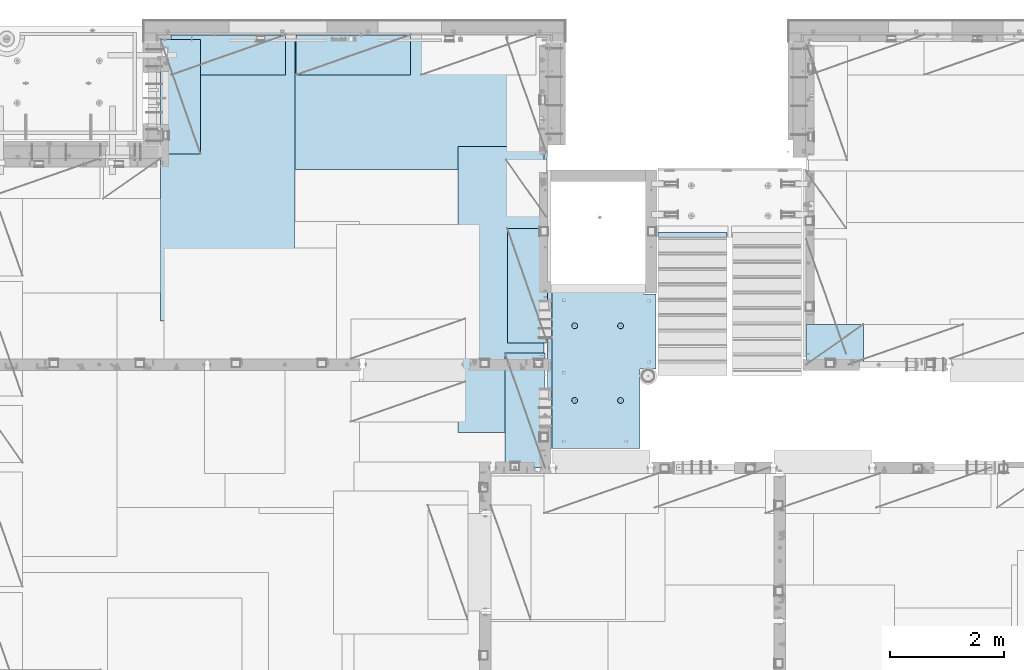
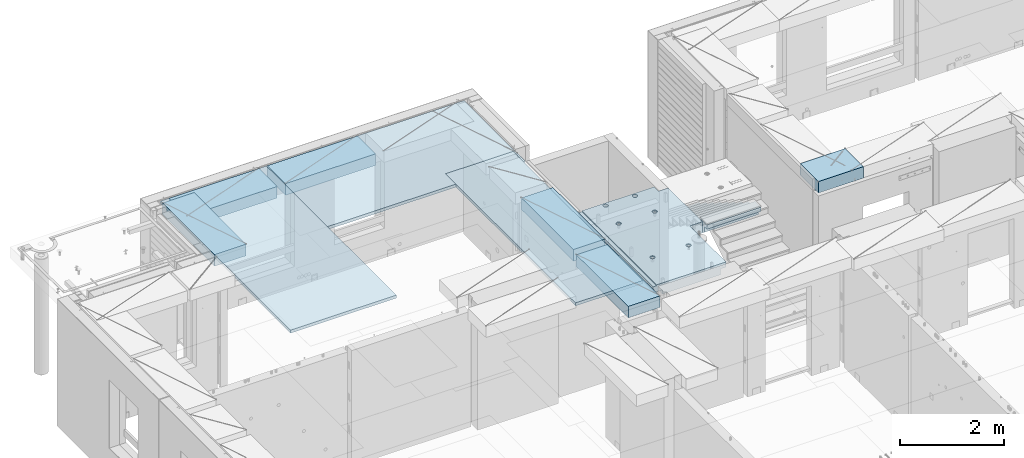
# One storey, part 199 of 334: 10 plates, 1 slab, 11 elements without a shape of their own.
"""IFC2X3 building model written with IfcOpenShell, lengths in millimetres."""

import ifcopenshell
import ifcopenshell.guid

model = None  # the IFC model being written
_history = None  # IfcOwnerHistory: only IFC2X3 demands one
_inside = {}  # id of a spatial element -> (the spatial element, [elements in it])
_under = {}  # id of a project, library or spatial element -> (it, [spatial elements below it])
_declared = {}  # id of a project -> (the project, [libraries it declares])
_typed = {}  # id of a type object -> (the type object, [elements of that type])
_made_of = {}  # id of a material, layer set ... -> (it, [elements and type objects made of it])


def new_model(schema):
    """Start an empty IFC model of exactly this schema.

    Asked for "IFC4X3", IfcOpenShell would pick the latest addendum, in which some entities
    have other attributes; the version numbers below select the first issue.
    IFC2X3 requires an IfcOwnerHistory on every rooted entity: one is made here for all.
    """
    global model, _history
    if schema == "IFC4X3":
        model = ifcopenshell.file(schema_version=(4, 3, 0, 0))
    else:
        model = ifcopenshell.file(schema=schema)
    _inside.clear()
    _under.clear()
    _declared.clear()
    _typed.clear()
    _made_of.clear()
    _history = None
    if model.schema == "IFC2X3":
        org = make("IfcOrganization", Name="unknown")
        user = make(
            "IfcPersonAndOrganization",
            ThePerson=make("IfcPerson", FamilyName="unknown"),
            TheOrganization=org,
        )
        app = make(
            "IfcApplication",
            ApplicationDeveloper=org,
            Version="unknown",
            ApplicationFullName="unknown",
            ApplicationIdentifier="unknown",
        )
        _history = make(
            "IfcOwnerHistory",
            OwningUser=user,
            OwningApplication=app,
            ChangeAction="ADDED",
            CreationDate=0,
        )
    return model


def make(cls, **values):
    """One entity of the class cls with the attributes given. An attribute that is None is left unset."""
    return model.create_entity(
        cls, **{name: value for name, value in values.items() if value is not None}
    )


def rooted(cls, **values):
    """An entity with a GlobalId (a new one), such as an element, a storey or a relation."""
    return make(cls, GlobalId=ifcopenshell.guid.new(), OwnerHistory=_history, **values)


def si_unit(unit_type, name, prefix=None):
    """IfcSIUnit, for example si_unit("LENGTHUNIT", "METRE", prefix="MILLI")."""
    return make("IfcSIUnit", UnitType=unit_type, Prefix=prefix, Name=name)


def assignment(units):
    """IfcUnitAssignment: the units of a project."""
    return None if units is None else make("IfcUnitAssignment", Units=units)


def point(xyz):
    """IfcCartesianPoint."""
    return None if xyz is None else make("IfcCartesianPoint", Coordinates=xyz)


def direction(xyz):
    """IfcDirection."""
    return None if xyz is None else make("IfcDirection", DirectionRatios=xyz)


def frame(location, z_axis=None, x_axis=None):
    """IfcAxis2Placement3D, a coordinate frame: its origin and axes. An axis left out is left unset."""
    return make(
        "IfcAxis2Placement3D",
        Location=point(location),
        Axis=direction(z_axis),
        RefDirection=direction(x_axis),
    )


def origin_with_axes():
    """The frame at (0, 0, 0) with the z axis (0, 0, 1) and the x axis (1, 0, 0) written out."""
    return frame((0.0, 0.0, 0.0), z_axis=(0.0, 0.0, 1.0), x_axis=(1.0, 0.0, 0.0))


def place(relative_to, where):
    """IfcLocalPlacement: puts the frame where relative to a parent placement (None: the world)."""
    return make(
        "IfcLocalPlacement", PlacementRelTo=relative_to, RelativePlacement=where
    )


def context(
    kind, dimensions, precision=None, world=None, true_north=None, identifier=None
):
    """IfcGeometricRepresentationContext, for example the 3D "Model" context."""
    return make(
        "IfcGeometricRepresentationContext",
        ContextIdentifier=identifier,
        ContextType=kind,
        CoordinateSpaceDimension=dimensions,
        Precision=precision,
        WorldCoordinateSystem=world,
        TrueNorth=true_north,
    )


def subcontext(parent, identifier, kind, view, scale=None):
    """IfcGeometricRepresentationSubContext, for example "Body" below "Model"."""
    return make(
        "IfcGeometricRepresentationSubContext",
        ContextIdentifier=identifier,
        ContextType=kind,
        ParentContext=parent,
        TargetScale=scale,
        TargetView=view,
    )


def project(units=None, contexts=None):
    """IfcProject with its units and contexts."""
    return rooted(
        "IfcProject",
        Name="project",
        RepresentationContexts=contexts,
        UnitsInContext=assignment(units),
    )


def spatial(cls, under=None, at=None, **own):
    """A site, building, storey or space (cls), placed at a placement, below another one or the project."""
    s = rooted(cls, ObjectPlacement=at, **own)
    if under is not None:
        _under.setdefault(under.id(), (under, []))[1].append(s)
    return s


def faces_of(points, faces, orient=None, outer=None):
    """IfcFace entities. A face is a list of loops; a loop is a list of indices into points, from 0.

    orient and outer hold one flag for each loop. By default every Orientation is true, the
    first loop of a face is its IfcFaceOuterBound and the others are IfcFaceBound.
    """
    made = []
    for i, loops in enumerate(faces):
        bounds = []
        for j, loop in enumerate(loops):
            is_outer = j == 0 if outer is None else outer[i][j]
            bounds.append(
                make(
                    "IfcFaceOuterBound" if is_outer else "IfcFaceBound",
                    Bound=make("IfcPolyLoop", Polygon=[points[k] for k in loop]),
                    Orientation=True if orient is None else orient[i][j],
                )
            )
        made.append(make("IfcFace", Bounds=bounds))
    return made


def faceted_brep(points, faces, orient=None, outer=None, voids=None):
    """IfcFacetedBrep: a solid bounded by flat faces; with voids (closed shells), ...WithVoids."""
    shared = [point(p) for p in points]
    hull = make("IfcClosedShell", CfsFaces=faces_of(shared, faces, orient, outer))
    if voids is None:
        return make("IfcFacetedBrep", Outer=hull)
    return make(
        "IfcFacetedBrepWithVoids",
        Outer=hull,
        Voids=[
            make(cls, CfsFaces=faces_of(shared, fs, o, b)) for cls, fs, o, b in voids
        ],
    )


def shape(context_of_items, identifier, shape_type, items):
    """IfcShapeRepresentation: the items that make up one representation, for example the "Body"."""
    return make(
        "IfcShapeRepresentation",
        ContextOfItems=context_of_items,
        RepresentationIdentifier=identifier,
        RepresentationType=shape_type,
        Items=items,
    )


def material(Name=None, Category=None):
    """IfcMaterial."""
    return make("IfcMaterial", Name=Name, Category=Category)


def made_of(thing, what):
    """Note that an element or type object is made of a material, layer set ...; save() writes the relation."""
    if what is not None:
        _made_of.setdefault(what.id(), (what, []))[1].append(thing)
    return thing


def type_object(cls, material=None, **own):
    """A type object (cls), such as IfcWallType, which elements share."""
    return made_of(rooted(cls, **own), material)


def element(
    cls,
    number,
    at=None,
    inside=None,
    cuts=None,
    type_object=None,
    material=None,
    context=None,
    identifier="Body",
    shape_type=None,
    held_by="IfcProductDefinitionShape",
    body=None,
    shapes=None,
    **own,
):
    """One element of the class cls, such as IfcWall. Its Tag is "e" and its number.

    at: its placement. inside: the storey or other place that contains it. cuts: it is an
    opening in that element (IfcRelVoidsElement). A single representation is given by context,
    identifier, shape_type and body (its items); several are given by shapes. held_by: the class
    of the entity that holds the representations. save() writes the other relations.
    """
    e = rooted(cls, Tag="e%d" % number, ObjectPlacement=at, **own)
    if body is not None:
        shapes = [shape(context, identifier, shape_type, body)]
    if shapes is not None:
        e.Representation = make(held_by, Representations=shapes)
    if inside is not None:
        _inside.setdefault(inside.id(), (inside, []))[1].append(e)
    if cuts is not None:
        rooted(
            "IfcRelVoidsElement", RelatingBuildingElement=cuts, RelatedOpeningElement=e
        )
    if type_object is not None:
        _typed.setdefault(type_object.id(), (type_object, []))[1].append(e)
    return made_of(e, material)


def aggregate(whole, parts):
    """IfcRelAggregates: a whole, such as a stair, and the parts it consists of."""
    return rooted("IfcRelAggregates", RelatingObject=whole, RelatedObjects=parts)


def save(model, path):
    """Write the relations noted so far, then the file.

    IfcRelAggregates (storeys below a building ...), IfcRelContainedInSpatialStructure (elements
    in a storey), IfcRelDefinesByType, IfcRelAssociatesMaterial and IfcRelDeclares: one each for
    every whole, place, type object, material and project.
    """
    for whole, parts in _under.values():
        aggregate(whole, parts)
    for where, things in _inside.values():
        rooted(
            "IfcRelContainedInSpatialStructure",
            RelatedElements=things,
            RelatingStructure=where,
        )
    for kind, things in _typed.values():
        rooted("IfcRelDefinesByType", RelatedObjects=things, RelatingType=kind)
    for what, things in _made_of.values():
        rooted("IfcRelAssociatesMaterial", RelatedObjects=things, RelatingMaterial=what)
    for by, libraries in _declared.values():
        rooted("IfcRelDeclares", RelatingContext=by, RelatedDefinitions=libraries)
    model.write(path)


model = new_model("IFC2X3")

# Units and contexts
model_context = context("Model", 3, precision=1e-05, world=origin_with_axes())
body_context = subcontext(model_context, "Body", "Model", "MODEL_VIEW")
ifc_project = project(units=[si_unit("LENGTHUNIT", "METRE", prefix="MILLI"), si_unit("AREAUNIT", "SQUARE_METRE"), si_unit("VOLUMEUNIT", "CUBIC_METRE"), si_unit("MASSUNIT", "GRAM", prefix="KILO"), si_unit("TIMEUNIT", "SECOND"), si_unit("PLANEANGLEUNIT", "RADIAN"), si_unit("SOLIDANGLEUNIT", "STERADIAN"), si_unit("THERMODYNAMICTEMPERATUREUNIT", "DEGREE_CELSIUS"), si_unit("LUMINOUSINTENSITYUNIT", "LUMEN")], contexts=[model_context])

# Site, building, storey
site_placement = place(None, origin_with_axes())
site = spatial("IfcSite", under=ifc_project, at=site_placement, CompositionType="ELEMENT")
building_placement = place(site_placement, origin_with_axes())
building = spatial("IfcBuilding", under=site, at=building_placement, CompositionType="ELEMENT")
storey_placement = place(building_placement, origin_with_axes())
storey = spatial("IfcBuildingStorey", under=building, at=storey_placement, Name="3", CompositionType="ELEMENT", Elevation=0.0)

# Assembly, plate
assembly_1_placement = place(storey_placement, origin_with_axes())
assembly_1 = element("IfcElementAssembly", 1, at=assembly_1_placement, inside=storey, Name="E9", AssemblyPlace="NOTDEFINED", PredefinedType="NOTDEFINED")
ifc_material_1 = material(Name="Undefined/C32/40")
plate_type_1 = type_object("IfcPlateType", PredefinedType="NOTDEFINED")
plate_1_placement = place(assembly_1_placement, frame((20285.0002457424, 19199.9998138874, 89260.0), z_axis=(0.0, -1.0, 0.0), x_axis=(0.0, 0.0, -1.0)))
plate_1 = element("IfcPlate", 2, at=plate_1_placement, type_object=plate_type_1, material=ifc_material_1, Name="E9", context=body_context, shape_type="Brep", body=[
    faceted_brep([(0.0, -600.0, 0.0), (0.0, -600.0, 30.0), (0.0, 600.0, 30.0), (0.0, 600.0, 0.0), (-136.699996948242, -600.0, 30.0), (-136.699996948242, 600.0, 30.0), (-136.699996948242, -600.0, 300.0), (-136.699996948242, 600.0, 300.0), (-303.399993896484, -600.0, 300.0), (-303.399993896484, 600.0, 300.0), (-303.399993896484, -600.0, 570.0), (-303.399993896484, 600.0, 570.0), (-470.100006103516, -600.0, 570.0), (-470.100006103516, 600.0, 570.0), (-470.100006103516, -600.0, 840.0), (-470.100006103516, 600.0, 840.0), (-636.799987792969, -600.0, 840.0), (-636.799987792969, 600.0, 840.0), (-636.799987792969, -600.0, 1110.0), (-636.799987792969, 600.0, 1110.0), (-803.5, -600.0, 1110.0), (-803.5, 600.0, 1110.0), (-803.5, -600.0, 1380.0), (-803.5, 600.0, 1380.0), (-970.200012207031, -600.0, 1380.0), (-970.200012207031, 600.0, 1380.0), (-970.200012207031, -600.0, 1650.0), (-970.200012207031, 600.0, 1650.0), (-1136.90002441406, -600.0, 1650.0), (-1136.90002441406, 600.0, 1650.0), (-1136.90002441406, -600.0, 1920.0), (-1136.90002441406, 600.0, 1920.0), (-1303.59997558594, -600.0, 1920.0), (-1303.59997558594, 600.0, 1920.0), (-1303.59997558594, -600.0, 2190.0), (-1303.59997558594, 600.0, 2190.0), (-1470.30004882813, -600.0, 2190.0), (-1470.30004882813, 600.0, 2190.0), (-1470.30004882813, -600.0, 2410.0), (-1470.30004882813, 600.0, 2410.0), (-1370.30004882813, -600.0, 2410.0), (-1370.30004882813, 600.0, 2410.0), (-1370.30004882813, -600.0, 2310.0), (-1370.30004882813, 600.0, 2310.0), (-1236.65991210938, -600.0, 2310.0), (-1236.65991210938, 600.0, 2310.0), (170.0, -600.0, 31.6665592193604), (170.0, 600.0, 31.6665592193604), (170.0, -600.0, 20.0), (170.0, 600.0, 20.0), (135.0, -600.0, 20.0), (135.0, 600.0, 20.0), (135.0, -600.0, -90.0), (135.0, 600.0, -90.0), (25.0, -600.0, -90.0), (25.0, 600.0, -90.0), (25.0, -600.0, 0.0), (25.0, 600.0, 0.0)], [[[0, 1, 2, 3]], [[1, 4, 5, 2]], [[4, 6, 7, 5]], [[6, 8, 9, 7]], [[8, 10, 11, 9]], [[10, 12, 13, 11]], [[12, 14, 15, 13]], [[14, 16, 17, 15]], [[16, 18, 19, 17]], [[18, 20, 21, 19]], [[20, 22, 23, 21]], [[22, 24, 25, 23]], [[24, 26, 27, 25]], [[26, 28, 29, 27]], [[28, 30, 31, 29]], [[30, 32, 33, 31]], [[32, 34, 35, 33]], [[34, 36, 37, 35]], [[36, 38, 39, 37]], [[38, 40, 41, 39]], [[40, 42, 43, 41]], [[42, 44, 45, 43]], [[44, 46, 47, 45]], [[46, 48, 49, 47]], [[48, 50, 51, 49]], [[50, 52, 53, 51]], [[52, 54, 55, 53]], [[54, 56, 57, 55]], [[56, 0, 3, 57]], [[5, 7, 9, 11, 13, 15, 17, 19, 21, 23, 25, 27, 29, 31, 33, 35, 37, 39, 41, 43, 45, 47, 49, 51, 53, 55, 57, 3, 2]], [[56, 54, 52, 50, 48, 46, 44, 42, 40, 38, 36, 34, 32, 30, 28, 26, 24, 22, 20, 18, 16, 14, 12, 10, 8, 6, 4, 1, 0]]]),
])
aggregate(assembly_1, [plate_1])

# Assembly, slab
assembly_2_placement = place(storey_placement, origin_with_axes())
assembly_2 = element("IfcElementAssembly", 3, at=assembly_2_placement, inside=storey, AssemblyPlace="NOTDEFINED", PredefinedType="REINFORCEMENT_UNIT")
ifc_material_2 = material(Name="CONCRETE/C25/30")
slab_type = type_object("IfcSlabType", PredefinedType="NOTDEFINED")
slab_placement = place(assembly_2_placement, frame((19370.0122708302, 15509.9992031236, 90620.0), z_axis=(-0.999999999999509, -9.91000000794397e-07, 0.0), x_axis=(-1.19799915409591e-06, 0.999999999999282, 0.0)))
slab = element("IfcSlab", 4, at=slab_placement, type_object=slab_type, material=ifc_material_2, PredefinedType="FLOOR", context=body_context, shape_type="Brep", body=[
    faceted_brep([(0.00270234311210515, 30.0, 1600.01636881603), (700.003686840937, 30.0, 1600.01632471597), (700.003459213352, 30.0, 1410.0099940095), (0.0034592138545122, 30.0, 1410.0108326095), (700.003459213352, 130.0, 1410.0099940095), (700.003686840937, 50.0008724475629, 1600.01632471597), (700.003710793628, 50.0008724475629, 1620.01159965654), (700.003710793628, 130.0, 1620.01159965654), (0.00238143379829125, 130.0, 1410.01083261132), (2149.99368684227, 30.0, 1600.01623336659), (2149.99345921271, 30.0, 1410.00825692148), (1649.99345921307, 30.0, 1410.00885592148), (1649.99368684195, 30.0, 1600.01626486659), (1390.00354003907, -130.0, -1.24055077321827e-09), (0.0, -130.0, -3.63797880709171e-12), (0.0, -10.0, 0.0), (1390.00503210942, -10.0000000000582, -8.29459168016911e-10), (0.00020267313993827, -10.0000000000582, 119.999691808891), (1390.0049992294, -10.0000000000582, 120.000072670202), (1390.0049992294, 129.999999999942, 120.000072670202), (0.000202673141757259, 130.0, 119.999691808891), (1390.00354003907, 130.0, -1.24055077321827e-09), (1390.00305175782, -130.0, -279.993591308594), (1390.00350516116, 130.0, -19.9999273271205), (1390.00305175782, 130.0, -279.993591308594), (2704.99731446005, 130.0, -279.993808230734), (2704.99731446008, -130.0, -279.993645464809), (2704.99757802008, 130.0, -59.9936454649687), (2704.99757802008, -130.000000000015, -59.9936454649687), (2869.99708830242, -130.0, -59.9938431343799), (2869.99708830242, 130.0, -59.9938431343799), (2869.99538188219, 50.0011350165441, 1600.0161880065), (2869.99536132813, 50.0011350165441, 1620.01123046875), (2149.99371079323, 50.0010478963522, 1620.01135296499), (2149.99368684227, 50.0010478963377, 1600.0162333666), (2869.99536132813, -109.999999999985, 1620.01123046875), (0.00273611420016096, -109.999999999985, 1620.01171875), (0.0026009984267148, -109.999999999985, 1540.01171889739), (2869.99544356416, -109.999999999985, 1540.01180212718), (2869.99536132813, -49.9988649834559, 1620.01123046875), (0.00273611420016096, -49.9992122525582, 1620.01171875), (2869.99538188219, -49.9988649834559, 1600.01618800648), (0.00270234311210515, -49.9992122525582, 1600.01636881602), (2869.99544356416, -129.999999999985, 1540.01180212718), (2869.99536132813, 130.0, 1620.01123046875), (2149.99371079323, 130.0, 1620.01135296499), (2149.99345921271, 130.0, 1410.00825692148), (1649.99345921307, 130.0, 1410.00885592148), (1649.99371079351, 130.0, 1620.01143803163), (1649.99371079351, 50.0009873963572, 1620.01143803163), (1649.99368684195, 50.0009873963427, 1600.0162648666), (0.0026009984267148, -130.0, 1540.01171889739), (858.080152798024, -110.0, 1097.45747495204), (872.018574202059, -110.0, 1104.55943434983), (883.080174557956, -110.0, 1115.62100820216), (890.182167352177, -110.0, 1129.55941258986), (892.62936004754, -110.0, 1145.01025937688), (890.182204372413, -110.0, 1160.46111202734), (883.08024497463, -110.0, 1174.39953343137), (872.018671122296, -110.0, 1185.46113378727), (858.080266734594, -110.0, 1192.56312658148), (842.629419947572, -110.0, 1195.01031927685), (827.178567297122, -110.0, 1192.56316360172), (813.240145893089, -110.0, 1185.46120420394), (802.178545537192, -110.0, 1174.3996303516), (795.076552742968, -110.0, 1160.46122596391), (792.629360047609, -110.0, 1145.01037917688), (795.076515722732, -110.0, 1129.55952652643), (802.178475120518, -110.0, 1115.62110512239), (813.240048972852, -110.0, 1104.5595047665), (827.178453360551, -110.0, 1097.45751197228), (842.629300147573, -110.0, 1095.01031927692), (858.782461559409, -130.0, 1095.29598202818), (842.629297424846, -130.0, 1092.73759200419), (873.354447572716, -130.0, 1102.72075776224), (884.918847944788, -130.0, 1114.28513042604), (892.343658593298, -130.0, 1128.85709864954), (894.902087320264, -130.0, 1145.01025665415), (892.34369729627, -130.0, 1161.16342078871), (884.918921562221, -130.0, 1175.73540680203), (873.354548898418, -130.0, 1187.29980717409), (858.782580674915, -130.0, 1194.72461782261), (842.629422670299, -130.0, 1197.28304654957), (826.476258535738, -130.0, 1194.72465652558), (811.90427252243, -130.0, 1187.29988079152), (800.339872150354, -130.0, 1175.73550812773), (792.915061501848, -130.0, 1161.16353990422), (790.356632774883, -130.0, 1145.01038189961), (792.915022798874, -130.0, 1128.85721776505), (800.339798532925, -130.0, 1114.28523175174), (811.904171196727, -130.0, 1102.72083137967), (826.476139420232, -130.0, 1095.29602073116), (858.08015281103, -110.0, 296.158841760913), (872.018574215066, -110.0, 303.2608011587), (883.080174570961, -110.0, 314.322375011034), (890.182167365187, -110.0, 328.26077939873), (892.629360060546, -110.0, 343.711626185755), (890.182204385423, -110.0, 359.162478836206), (883.080244987636, -110.0, 373.100900240239), (872.018671135302, -110.0, 384.16250059614), (858.0802667476, -110.0, 391.264493390358), (842.62941996058, -110.0, 393.711686085717), (827.178567310128, -110.0, 391.264530410594), (813.240145906095, -110.0, 384.16257101281), (802.178545550198, -110.0, 373.100997160473), (795.076552755974, -110.0, 359.162592772776), (792.629360060615, -110.0, 343.711745985755), (795.076515735738, -110.0, 328.2608933353), (802.178475133525, -110.0, 314.322471931268), (813.240048985859, -110.0, 303.26087157537), (827.178453373557, -110.0, 296.158878781149), (842.629300160579, -110.0, 293.71168608579), (858.782461572417, -130.0, 293.997348837052), (842.629297437852, -130.0, 291.438958813062), (873.354447585723, -130.0, 301.422124571109), (884.918847957797, -130.0, 312.98649723491), (892.343658606304, -130.0, 327.558465458413), (894.90208733327, -130.0, 343.711623463027), (892.343697309276, -130.0, 359.864787597588), (884.918921575227, -130.0, 374.436773610898), (873.354548911424, -130.0, 386.001173982968), (858.782580687921, -130.0, 393.425984631478), (842.629422683307, -130.0, 395.984413358441), (826.476258548744, -130.0, 393.426023334454), (811.904272535436, -130.0, 386.001247600398), (800.339872163362, -130.0, 374.4368749366), (792.915061514856, -130.0, 359.864906713094), (790.356632787889, -130.0, 343.711748708483), (792.915022811882, -130.0, 327.558584573919), (800.339798545931, -130.0, 312.986598560612), (811.904171209735, -130.0, 301.422198188538), (826.47613943324, -130.0, 293.997387540028), (2162.44895919675, -110.0, 1097.45754446905), (2176.38738060079, -110.0, 1104.55950386684), (2187.44898095669, -110.0, 1115.62107771917), (2194.55097375091, -110.0, 1129.55948210687), (2196.99816644627, -110.0, 1145.0103288939), (2194.55101077115, -110.0, 1160.46118154435), (2187.44905137336, -110.0, 1174.39960294838), (2176.38747752102, -110.0, 1185.46120330428), (2162.44907313332, -110.0, 1192.5631960985), (2146.9982263463, -110.0, 1195.01038879386), (2131.54737369585, -110.0, 1192.56323311873), (2117.60895229182, -110.0, 1185.46127372095), (2106.54735193592, -110.0, 1174.39969986862), (2099.4453591417, -110.0, 1160.46129548092), (2096.99816644634, -110.0, 1145.01044869389), (2099.44532212146, -110.0, 1129.55959604344), (2106.54728151925, -110.0, 1115.62117463941), (2117.60885537159, -110.0, 1104.55957428351), (2131.54725975928, -110.0, 1097.45758148929), (2146.9981065463, -110.0, 1095.01038879393), (2163.15126795814, -130.0, 1095.2960515452), (2146.99810382357, -130.0, 1092.73766152121), (2177.72325397145, -130.0, 1102.72082727925), (2189.28765434352, -130.0, 1114.28519994305), (2196.71246499203, -130.0, 1128.85716816655), (2199.27089371899, -130.0, 1145.01032617117), (2196.71250369501, -130.0, 1161.16349030573), (2189.28772796095, -130.0, 1175.73547631904), (2177.72335529715, -130.0, 1187.29987669111), (2163.15138707365, -130.0, 1194.72468733962), (2146.99822906903, -130.0, 1197.28311606658), (2130.84506493447, -130.0, 1194.72472604259), (2116.27307892116, -130.0, 1187.29995030854), (2104.70867854909, -130.0, 1175.73557764474), (2097.28386790058, -130.0, 1161.16360942123), (2094.72543917361, -130.0, 1145.01045141662), (2097.2838291976, -130.0, 1128.85728728206), (2104.70860493166, -130.0, 1114.28530126875), (2116.27297759546, -130.0, 1102.72090089668), (2130.84494581896, -130.0, 1095.29609024817), (2162.44895913772, -110.0, 296.158911320326), (2176.38738054176, -110.0, 303.260870718113), (2187.44898089765, -110.0, 314.322444570447), (2194.55097369188, -110.0, 328.260848958147), (2196.99816638724, -110.0, 343.711695745169), (2194.55101071211, -110.0, 359.162548395623), (2187.44905131433, -110.0, 373.100969799652), (2176.38747746199, -110.0, 384.162570155553), (2162.44907307429, -110.0, 391.264562949771), (2146.99822628727, -110.0, 393.711755645134), (2131.54737363682, -110.0, 391.264599970007), (2117.60895223279, -110.0, 384.162640572227), (2106.54735187689, -110.0, 373.10106671989), (2099.44535908267, -110.0, 359.162662332194), (2096.99816638731, -110.0, 343.711815545168), (2099.44532206243, -110.0, 328.260962894718), (2106.54728146021, -110.0, 314.322541490685), (2117.60885531255, -110.0, 303.260941134788), (2131.54725970025, -110.0, 296.158948340562), (2146.99810648727, -110.0, 293.711755645207), (2163.15126789911, -130.0, 293.997418396466), (2146.99810376454, -130.0, 291.439028372479), (2177.72325391241, -130.0, 301.422194130522), (2189.28765428449, -130.0, 312.986566794323), (2196.712464933, -130.0, 327.558535017826), (2199.27089365996, -130.0, 343.711693022444), (2196.71250363597, -130.0, 359.864857157001), (2189.28772790192, -130.0, 374.436843170311), (2177.72335523811, -130.0, 386.001243542381), (2163.15138701461, -130.0, 393.426054190892), (2146.99822901, -130.0, 395.984482917858), (2130.84506487544, -130.0, 393.426092893867), (2116.27307886213, -130.0, 386.001317159811), (2104.70867849006, -130.0, 374.436944496014), (2097.28386784155, -130.0, 359.864976272507), (2094.72543911458, -130.0, 343.711818267897), (2097.28382913857, -130.0, 327.558654133332), (2104.70860487263, -130.0, 312.986668120026), (2116.27297753642, -130.0, 301.422267747952), (2130.84494575993, -130.0, 293.997457099442), (2805.44844412025, -130.0, 362.453408379821), (2805.44844412025, 130.0, 362.453408379821), (2789.9975914698, 130.0, 360.006252704694), (2789.9975914698, -130.0, 360.006252704694), (2819.38686552428, -130.0, 369.555367777604), (2819.38686552428, 130.0, 369.555367777604), (2830.44846588018, -130.0, 380.616941629942), (2830.44846588018, 130.0, 380.616941629942), (2837.5504586744, -130.0, 394.555346017638), (2837.5504586744, 130.0, 394.555346017638), (2839.99765136976, -130.0, 410.006192804663), (2839.99765136976, 130.0, 410.006192804663), (2837.55049569464, -130.0, 425.457045455114), (2837.55049569464, 130.0, 425.457045455114), (2830.44853629686, -130.0, 439.395466859147), (2830.44853629686, 130.0, 439.395466859147), (2819.38696244451, -130.0, 450.457067215044), (2819.38696244451, 130.0, 450.457067215044), (2805.44855805682, -130.0, 457.559060009266), (2805.44855805682, 130.0, 457.559060009266), (2789.9977112698, -130.0, 460.006252704625), (2789.9977112698, 130.0, 460.006252704625), (2774.54685861935, -130.0, 457.559097029502), (2774.54685861935, 130.0, 457.559097029502), (2760.60843721531, -130.0, 450.457137631718), (2760.60843721531, 130.0, 450.457137631718), (2749.54683685942, -130.0, 439.395563779381), (2749.54683685942, 130.0, 439.395563779381), (2742.44484406519, -130.0, 425.457159391684), (2742.44484406519, 130.0, 425.457159391684), (2739.99765136983, -130.0, 410.006312604663), (2739.99765136983, 130.0, 410.006312604663), (2742.44480704495, -130.0, 394.555459954208), (2742.44480704495, 130.0, 394.555459954208), (2749.54676644274, -130.0, 380.617038550175), (2749.54676644274, 130.0, 380.617038550175), (2760.60834029508, -130.0, 369.555438194278), (2760.60834029508, 130.0, 369.555438194278), (2774.54674468278, -130.0, 362.453445400057), (2774.54674468278, 130.0, 362.453445400057), (2760.60911899507, -130.0, 1019.55543819397), (2749.54754514274, -130.0, 1030.61703854987), (2742.44558574495, -130.0, 1044.5554599539), (2739.99843006983, -130.0, 1060.00631260435), (2742.44562276519, -130.0, 1075.45715939137), (2749.54761555942, -130.0, 1089.39556377907), (2760.60921591531, -130.0, 1100.45713763141), (2774.54763731935, -130.0, 1107.55909702919), (2789.9984899698, -130.0, 1110.00625270432), (2805.44933675682, -130.0, 1107.55906000896), (2819.38774114452, -130.0, 1100.45706721473), (2830.44931499685, -130.0, 1089.39546685884), (2837.55127439463, -130.0, 1075.4570454548), (2839.99843006976, -130.0, 1060.00619280435), (2837.5512373744, -130.0, 1044.55534601733), (2830.44924458018, -130.0, 1030.61694162963), (2819.38764422428, -130.0, 1019.55536777729), (2805.44922282025, -130.0, 1012.45340837951), (2789.9983701698, -130.0, 1010.00625270438), (2774.54752338277, -130.0, 1012.45344539975), (2819.38764422428, 130.0, 1019.55536777729), (2805.44922282025, 130.0, 1012.45340837951), (2830.44924458018, 130.0, 1030.61694162963), (2837.5512373744, 130.0, 1044.55534601733), (2839.99843006976, 130.0, 1060.00619280435), (2837.55127439463, 130.0, 1075.4570454548), (2830.44931499685, 130.0, 1089.39546685884), (2819.38774114452, 130.0, 1100.45706721473), (2805.44933675682, 130.0, 1107.55906000896), (2789.9984899698, 130.0, 1110.00625270432), (2774.54763731935, 130.0, 1107.55909702919), (2760.60921591531, 130.0, 1100.45713763141), (2749.54761555942, 130.0, 1089.39556377907), (2742.44562276519, 130.0, 1075.45715939137), (2739.99843006983, 130.0, 1060.00631260435), (2742.44558574495, 130.0, 1044.5554599539), (2749.54754514274, 130.0, 1030.61703854987), (2760.60911899507, 130.0, 1019.55543819397), (2774.54752338277, 130.0, 1012.45344539975), (2789.9983701698, 130.0, 1010.00625270438)], [[[0, 1, 2, 3]], [[4, 2, 1, 5, 6, 7]], [[8, 3, 2, 4]], [[9, 10, 11, 12]], [[13, 14, 15, 16]], [[15, 17, 18, 16]], [[19, 18, 17, 20]], [[16, 18, 19, 21]], [[22, 13, 16, 21, 23, 24]], [[22, 24, 25, 26]], [[26, 25, 27, 28]], [[29, 28, 27, 30]], [[31, 32, 33, 34]], [[35, 36, 37, 38]], [[36, 35, 39, 40]], [[41, 42, 40, 39]], [[35, 38, 43, 29, 30, 44, 32, 31, 41, 39]], [[32, 44, 45, 33]], [[46, 10, 9, 34, 33, 45]], [[47, 11, 10, 46]], [[48, 49, 50, 12, 11, 47]], [[49, 48, 7, 6]], [[50, 49, 6, 5]], [[42, 41, 31, 34, 9, 12, 50, 5, 1, 0]], [[20, 17, 15, 14, 51, 37, 36, 40, 42, 0, 3, 8]], [[43, 38, 37, 51]], [[52, 53, 54, 55, 56, 57, 58, 59, 60, 61, 62, 63, 64, 65, 66, 67, 68, 69, 70, 71]], [[72, 52, 71, 73]], [[74, 53, 52, 72]], [[75, 54, 53, 74]], [[76, 55, 54, 75]], [[77, 56, 55, 76]], [[78, 57, 56, 77]], [[79, 58, 57, 78]], [[80, 59, 58, 79]], [[81, 60, 59, 80]], [[82, 61, 60, 81]], [[83, 62, 61, 82]], [[84, 63, 62, 83]], [[85, 64, 63, 84]], [[86, 65, 64, 85]], [[87, 66, 65, 86]], [[88, 67, 66, 87]], [[89, 68, 67, 88]], [[90, 69, 68, 89]], [[91, 70, 69, 90]], [[73, 71, 70, 91]], [[92, 93, 94, 95, 96, 97, 98, 99, 100, 101, 102, 103, 104, 105, 106, 107, 108, 109, 110, 111]], [[112, 92, 111, 113]], [[114, 93, 92, 112]], [[115, 94, 93, 114]], [[116, 95, 94, 115]], [[117, 96, 95, 116]], [[118, 97, 96, 117]], [[119, 98, 97, 118]], [[120, 99, 98, 119]], [[121, 100, 99, 120]], [[122, 101, 100, 121]], [[123, 102, 101, 122]], [[124, 103, 102, 123]], [[125, 104, 103, 124]], [[126, 105, 104, 125]], [[127, 106, 105, 126]], [[128, 107, 106, 127]], [[129, 108, 107, 128]], [[130, 109, 108, 129]], [[131, 110, 109, 130]], [[113, 111, 110, 131]], [[132, 133, 134, 135, 136, 137, 138, 139, 140, 141, 142, 143, 144, 145, 146, 147, 148, 149, 150, 151]], [[152, 132, 151, 153]], [[154, 133, 132, 152]], [[155, 134, 133, 154]], [[156, 135, 134, 155]], [[157, 136, 135, 156]], [[158, 137, 136, 157]], [[159, 138, 137, 158]], [[160, 139, 138, 159]], [[161, 140, 139, 160]], [[162, 141, 140, 161]], [[163, 142, 141, 162]], [[164, 143, 142, 163]], [[165, 144, 143, 164]], [[166, 145, 144, 165]], [[167, 146, 145, 166]], [[168, 147, 146, 167]], [[169, 148, 147, 168]], [[170, 149, 148, 169]], [[171, 150, 149, 170]], [[153, 151, 150, 171]], [[172, 173, 174, 175, 176, 177, 178, 179, 180, 181, 182, 183, 184, 185, 186, 187, 188, 189, 190, 191]], [[192, 172, 191, 193]], [[194, 173, 172, 192]], [[195, 174, 173, 194]], [[196, 175, 174, 195]], [[197, 176, 175, 196]], [[198, 177, 176, 197]], [[199, 178, 177, 198]], [[200, 179, 178, 199]], [[201, 180, 179, 200]], [[202, 181, 180, 201]], [[203, 182, 181, 202]], [[204, 183, 182, 203]], [[205, 184, 183, 204]], [[206, 185, 184, 205]], [[207, 186, 185, 206]], [[208, 187, 186, 207]], [[209, 188, 187, 208]], [[210, 189, 188, 209]], [[211, 190, 189, 210]], [[193, 191, 190, 211]], [[212, 213, 214, 215]], [[216, 217, 213, 212]], [[218, 219, 217, 216]], [[220, 221, 219, 218]], [[222, 223, 221, 220]], [[224, 225, 223, 222]], [[226, 227, 225, 224]], [[228, 229, 227, 226]], [[230, 231, 229, 228]], [[232, 233, 231, 230]], [[234, 235, 233, 232]], [[236, 237, 235, 234]], [[238, 239, 237, 236]], [[240, 241, 239, 238]], [[242, 243, 241, 240]], [[244, 245, 243, 242]], [[246, 247, 245, 244]], [[248, 249, 247, 246]], [[250, 251, 249, 248]], [[215, 214, 251, 250]], [[14, 13, 22, 26, 28, 29, 43, 51], [252, 253, 254, 255, 256, 257, 258, 259, 260, 261, 262, 263, 264, 265, 266, 267, 268, 269, 270, 271], [248, 246, 244, 242, 240, 238, 236, 234, 232, 230, 228, 226, 224, 222, 220, 218, 216, 212, 215, 250], [210, 209, 208, 207, 206, 205, 204, 203, 202, 201, 200, 199, 198, 197, 196, 195, 194, 192, 193, 211], [170, 169, 168, 167, 166, 165, 164, 163, 162, 161, 160, 159, 158, 157, 156, 155, 154, 152, 153, 171], [130, 129, 128, 127, 126, 125, 124, 123, 122, 121, 120, 119, 118, 117, 116, 115, 114, 112, 113, 131], [90, 89, 88, 87, 86, 85, 84, 83, 82, 81, 80, 79, 78, 77, 76, 75, 74, 72, 73, 91]], [[268, 272, 273, 269]], [[267, 274, 272, 268]], [[266, 275, 274, 267]], [[265, 276, 275, 266]], [[264, 277, 276, 265]], [[263, 278, 277, 264]], [[262, 279, 278, 263]], [[261, 280, 279, 262]], [[260, 281, 280, 261]], [[259, 282, 281, 260]], [[258, 283, 282, 259]], [[257, 284, 283, 258]], [[256, 285, 284, 257]], [[255, 286, 285, 256]], [[254, 287, 286, 255]], [[253, 288, 287, 254]], [[252, 289, 288, 253]], [[271, 290, 289, 252]], [[270, 291, 290, 271]], [[269, 273, 291, 270]], [[48, 47, 46, 45, 44, 30, 27, 25, 24, 23, 21, 19, 20, 8, 4, 7], [272, 274, 275, 276, 277, 278, 279, 280, 281, 282, 283, 284, 285, 286, 287, 288, 289, 290, 291, 273], [217, 219, 221, 223, 225, 227, 229, 231, 233, 235, 237, 239, 241, 243, 245, 247, 249, 251, 214, 213]]]),
])
aggregate(assembly_2, [slab])

# Assembly, plate
assembly_3_placement = place(storey_placement, origin_with_axes())
assembly_3 = element("IfcElementAssembly", 5, at=assembly_3_placement, inside=storey, Name="Steel Assembly", AssemblyPlace="NOTDEFINED", PredefinedType="NOTDEFINED")
ifc_material_3 = material()
plate_type_2 = type_object("IfcPlateType", PredefinedType="NOTDEFINED")
plate_2_placement = place(assembly_3_placement, frame((12729.9998779297, 22740.0009765625, 90695.1), z_axis=(1.0, 0.0, 0.0), x_axis=(0.0, -1.0, 0.0)))
plate_2 = element("IfcPlate", 6, at=plate_2_placement, type_object=plate_type_2, material=ifc_material_3, context=body_context, shape_type="Brep", body=[
    faceted_brep([(0.0, -35.0, 0.0), (0.0, -35.0, 5000.0), (0.0, 35.0, 5000.0), (0.0, 35.0, 0.0), (2349.99951171875, -35.0, 5000.0), (2349.99951171875, 35.0, 5000.0), (2350.0, -35.0, 0.0), (2350.0, 35.0, 0.0)], [[[0, 1, 2, 3]], [[1, 4, 5, 2]], [[4, 6, 7, 5]], [[6, 0, 3, 7]], [[5, 7, 3, 2]], [[6, 4, 1, 0]]]),
])
aggregate(assembly_3, [plate_2])

assembly_4_placement = place(storey_placement, origin_with_axes())
assembly_4 = element("IfcElementAssembly", 7, at=assembly_4_placement, inside=storey, Name="Steel Assembly", AssemblyPlace="NOTDEFINED", PredefinedType="NOTDEFINED")
plate_3_placement = place(assembly_4_placement, frame((13340.0, 22740.0, 90695.1), z_axis=(0.0, -1.0, 0.0), x_axis=(-1.0, 3.00000001838171e-08, 0.0)))
plate_3 = element("IfcPlate", 8, at=plate_3_placement, type_object=plate_type_2, material=ifc_material_3, context=body_context, shape_type="Brep", body=[
    faceted_brep([(0.0, -35.0, 0.0), (0.0, -35.0, 5000.0), (0.0, 35.0, 5000.0), (0.0, 35.0, 0.0), (2349.99951171875, -35.0, 5000.0), (2349.99951171875, 35.0, 5000.0), (2350.0, -35.0, 0.0), (2350.0, 35.0, 0.0)], [[[0, 1, 2, 3]], [[1, 4, 5, 2]], [[4, 6, 7, 5]], [[6, 0, 3, 7]], [[5, 7, 3, 2]], [[6, 4, 1, 0]]]),
])
aggregate(assembly_4, [plate_3])

assembly_5_placement = place(storey_placement, origin_with_axes())
assembly_5 = element("IfcElementAssembly", 9, at=assembly_5_placement, inside=storey, Name="Steel Assembly", AssemblyPlace="NOTDEFINED", PredefinedType="NOTDEFINED")
plate_type_3 = type_object("IfcPlateType", PredefinedType="NOTDEFINED")
plate_4_placement = place(assembly_5_placement, frame((17690.0000122641, 20790.0, 90695.1000003815), z_axis=(0.0, -1.0, 0.0), x_axis=(-1.0, 3.00000001838171e-08, 0.0)))
plate_4 = element("IfcPlate", 10, at=plate_4_placement, type_object=plate_type_3, material=ifc_material_3, context=body_context, shape_type="Brep", body=[
    faceted_brep([(0.0, -35.0, 0.0), (0.0, -35.0, 5000.0), (0.0, 35.0, 5000.0), (0.0, 35.0, 0.0), (1499.99951171875, -35.0, 5000.0), (1499.99951171875, 35.0, 5000.0), (1500.0, -35.0, 0.0), (1500.0, 35.0, 0.0)], [[[0, 1, 2, 3]], [[1, 4, 5, 2]], [[4, 6, 7, 5]], [[6, 0, 3, 7]], [[5, 7, 3, 2]], [[6, 4, 1, 0]]]),
])
aggregate(assembly_5, [plate_4])

assembly_6_placement = place(storey_placement, origin_with_axes())
assembly_6 = element("IfcElementAssembly", 11, at=assembly_6_placement, inside=storey, Name="Steel Assembly", AssemblyPlace="NOTDEFINED", PredefinedType="NOTDEFINED")
plate_type_4 = type_object("IfcPlateType", PredefinedType="NOTDEFINED")
plate_5_placement = place(assembly_6_placement, frame((22270.0, 16979.9999999293, 90595.3), z_axis=(0.0, 1.0, 0.0), x_axis=(1.0, 0.0, 0.0)))
plate_5 = element("IfcPlate", 12, at=plate_5_placement, type_object=plate_type_4, material=ifc_material_3, Name="RE1_1/2", context=body_context, shape_type="Brep", body=[
    faceted_brep([(1.81898940354586e-12, -135.0, 1.81898940354586e-12), (0.0, -135.0, 699.999999999996), (0.0, 135.0, 699.999999999996), (1.81898940354586e-12, 135.0, 1.81898940354586e-12), (999.99951171875, -135.0, 700.0), (999.99951171875, 135.0, 700.0), (1000.0, -135.0, 0.0), (1000.0, 135.0, 0.0)], [[[0, 1, 2, 3]], [[1, 4, 5, 2]], [[4, 6, 7, 5]], [[6, 0, 3, 7]], [[5, 7, 3, 2]], [[6, 4, 1, 0]]]),
])
aggregate(assembly_6, [plate_5])

assembly_7_placement = place(storey_placement, origin_with_axes())
assembly_7 = element("IfcElementAssembly", 13, at=assembly_7_placement, inside=storey, Name="Steel Assembly", AssemblyPlace="NOTDEFINED", PredefinedType="NOTDEFINED")
plate_6_placement = place(assembly_7_placement, frame((17750.0001220703, 17360.0, 90595.3), z_axis=(-1.0, 3.00000001838171e-08, 0.0), x_axis=(0.0, 1.0, 0.0)))
plate_6 = element("IfcPlate", 14, at=plate_6_placement, type_object=plate_type_4, material=ifc_material_3, Name="RE1", context=body_context, shape_type="Brep", body=[
    faceted_brep([(1.81898940354586e-12, -135.0, 1.81898940354586e-12), (0.0, -135.0, 699.999999999996), (0.0, 135.0, 699.999999999996), (1.81898940354586e-12, 135.0, 1.81898940354586e-12), (1999.99951171875, -135.0, 699.999999999993), (1999.99951171875, 135.0, 699.999999999993), (2000.0, -135.0, -3.63797880709171e-12), (2000.0, 135.0, -3.63797880709171e-12)], [[[0, 1, 2, 3]], [[1, 4, 5, 2]], [[4, 6, 7, 5]], [[6, 0, 3, 7]], [[5, 7, 3, 2]], [[6, 4, 1, 0]]]),
])
aggregate(assembly_7, [plate_6])

assembly_8_placement = place(storey_placement, origin_with_axes())
assembly_8 = element("IfcElementAssembly", 15, at=assembly_8_placement, inside=storey, Name="Steel Assembly", AssemblyPlace="NOTDEFINED", PredefinedType="NOTDEFINED")
plate_7_placement = place(assembly_8_placement, frame((17710.0001220703, 15180.0, 90595.3), z_axis=(-1.0, 3.00000001838171e-08, 0.0), x_axis=(0.0, 1.0, 0.0)))
plate_7 = element("IfcPlate", 16, at=plate_7_placement, type_object=plate_type_4, material=ifc_material_3, Name="RE1", context=body_context, shape_type="Brep", body=[
    faceted_brep([(1.81898940354586e-12, -135.0, 1.81898940354586e-12), (0.0, -135.0, 699.999999999996), (0.0, 135.0, 699.999999999996), (1.81898940354586e-12, 135.0, 1.81898940354586e-12), (1999.99951171875, -135.0, 699.999999999993), (1999.99951171875, 135.0, 699.999999999993), (2000.0, -135.0, -3.63797880709171e-12), (2000.0, 135.0, -3.63797880709171e-12)], [[[0, 1, 2, 3]], [[1, 4, 5, 2]], [[4, 6, 7, 5]], [[6, 0, 3, 7]], [[5, 7, 3, 2]], [[6, 4, 1, 0]]]),
])
aggregate(assembly_8, [plate_7])

assembly_9_placement = place(storey_placement, origin_with_axes())
assembly_9 = element("IfcElementAssembly", 17, at=assembly_9_placement, inside=storey, Name="Steel Assembly", AssemblyPlace="NOTDEFINED", PredefinedType="NOTDEFINED")
plate_8_placement = place(assembly_9_placement, frame((13175.0, 22740.0001220703, 90595.3), z_axis=(0.0, -1.0, 0.0), x_axis=(-1.0, 3.00000001838171e-08, 0.0)))
plate_8 = element("IfcPlate", 18, at=plate_8_placement, type_object=plate_type_4, material=ifc_material_3, Name="RE1", context=body_context, shape_type="Brep", body=[
    faceted_brep([(1.81898940354586e-12, -135.0, 1.81898940354586e-12), (0.0, -135.0, 699.999999999996), (0.0, 135.0, 699.999999999996), (1.81898940354586e-12, 135.0, 1.81898940354586e-12), (1999.99951171875, -135.0, 699.999999999993), (1999.99951171875, 135.0, 699.999999999993), (2000.0, -135.0, -3.63797880709171e-12), (2000.0, 135.0, -3.63797880709171e-12)], [[[0, 1, 2, 3]], [[1, 4, 5, 2]], [[4, 6, 7, 5]], [[6, 0, 3, 7]], [[5, 7, 3, 2]], [[6, 4, 1, 0]]]),
])
aggregate(assembly_9, [plate_8])

assembly_10_placement = place(storey_placement, origin_with_axes())
assembly_10 = element("IfcElementAssembly", 19, at=assembly_10_placement, inside=storey, Name="Steel Assembly", AssemblyPlace="NOTDEFINED", PredefinedType="NOTDEFINED")
plate_9_placement = place(assembly_10_placement, frame((15360.0, 22740.0001220703, 90595.3), z_axis=(0.0, -1.0, 0.0), x_axis=(-1.0, 3.00000001838171e-08, 0.0)))
plate_9 = element("IfcPlate", 20, at=plate_9_placement, type_object=plate_type_4, material=ifc_material_3, Name="RE1", context=body_context, shape_type="Brep", body=[
    faceted_brep([(1.81898940354586e-12, -135.0, 1.81898940354586e-12), (0.0, -135.0, 699.999999999996), (0.0, 135.0, 699.999999999996), (1.81898940354586e-12, 135.0, 1.81898940354586e-12), (1999.99951171875, -135.0, 699.999999999993), (1999.99951171875, 135.0, 699.999999999993), (2000.0, -135.0, -3.63797880709171e-12), (2000.0, 135.0, -3.63797880709171e-12)], [[[0, 1, 2, 3]], [[1, 4, 5, 2]], [[4, 6, 7, 5]], [[6, 0, 3, 7]], [[5, 7, 3, 2]], [[6, 4, 1, 0]]]),
])
aggregate(assembly_10, [plate_9])

assembly_11_placement = place(storey_placement, origin_with_axes())
assembly_11 = element("IfcElementAssembly", 21, at=assembly_11_placement, inside=storey, Name="Steel Assembly", AssemblyPlace="NOTDEFINED", PredefinedType="NOTDEFINED")
plate_10_placement = place(assembly_11_placement, frame((10989.9998779297, 22660.0, 90595.3), z_axis=(1.0, 0.0, 0.0), x_axis=(0.0, -1.0, 0.0)))
plate_10 = element("IfcPlate", 22, at=plate_10_placement, type_object=plate_type_4, material=ifc_material_3, Name="RE1", context=body_context, shape_type="Brep", body=[
    faceted_brep([(1.81898940354586e-12, -135.0, 1.81898940354586e-12), (0.0, -135.0, 699.999999999996), (0.0, 135.0, 699.999999999996), (1.81898940354586e-12, 135.0, 1.81898940354586e-12), (1999.99951171875, -135.0, 699.999999999993), (1999.99951171875, 135.0, 699.999999999993), (2000.0, -135.0, -3.63797880709171e-12), (2000.0, 135.0, -3.63797880709171e-12)], [[[0, 1, 2, 3]], [[1, 4, 5, 2]], [[4, 6, 7, 5]], [[6, 0, 3, 7]], [[5, 7, 3, 2]], [[6, 4, 1, 0]]]),
])
aggregate(assembly_11, [plate_10])

save(model, "model.ifc")
